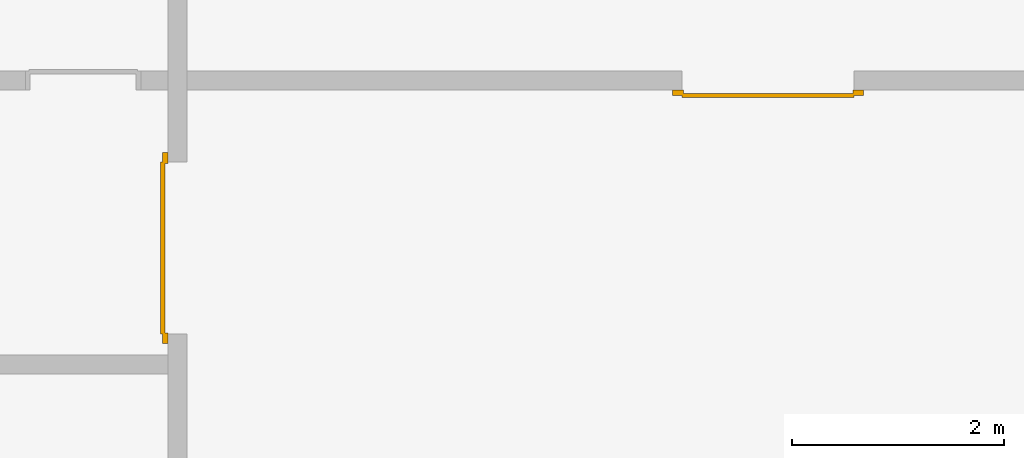
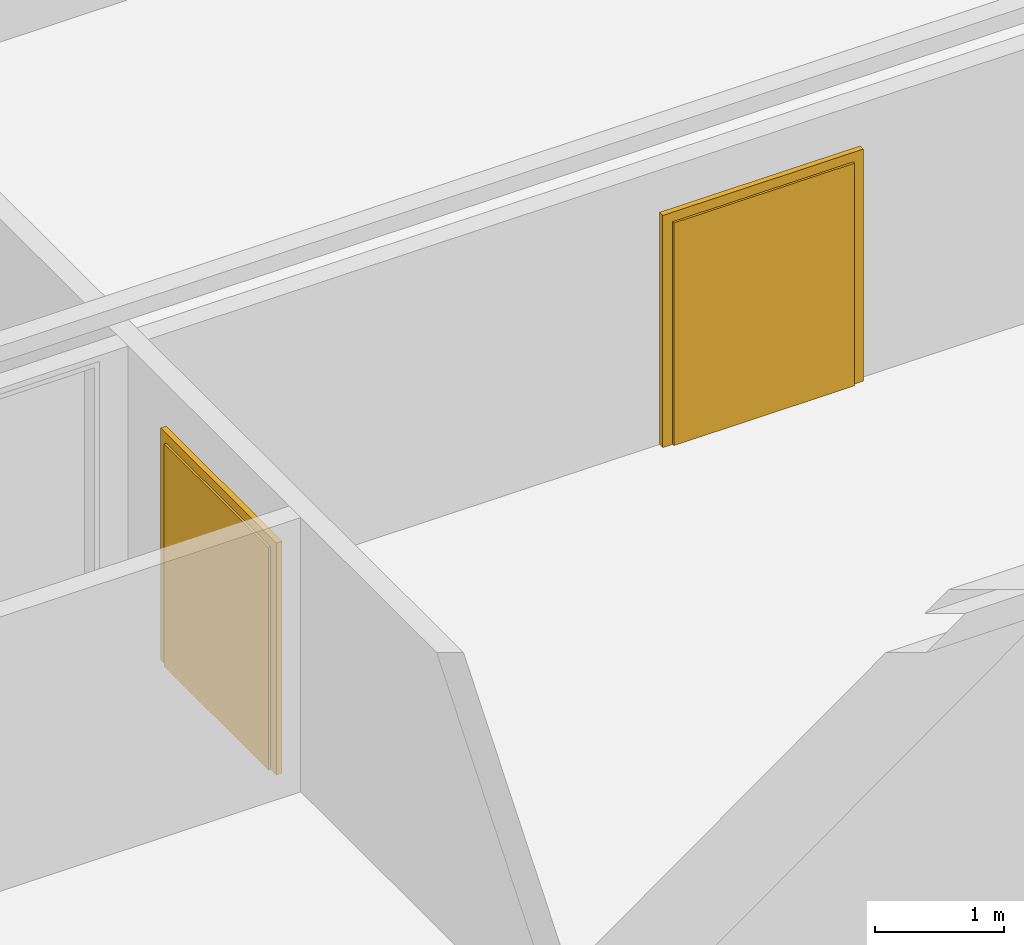
# One storey, part 3 of 5: 2 doors.
"""IFC4 building model written with IfcOpenShell, lengths in metres."""

import ifcopenshell
import ifcopenshell.guid

model = None  # the IFC model being written
_history = None  # IfcOwnerHistory: only IFC2X3 demands one
_inside = {}  # id of a spatial element -> (the spatial element, [elements in it])
_under = {}  # id of a project, library or spatial element -> (it, [spatial elements below it])
_declared = {}  # id of a project -> (the project, [libraries it declares])
_typed = {}  # id of a type object -> (the type object, [elements of that type])
_made_of = {}  # id of a material, layer set ... -> (it, [elements and type objects made of it])


def new_model(schema):
    """Start an empty IFC model of exactly this schema.

    Asked for "IFC4X3", IfcOpenShell would pick the latest addendum, in which some entities
    have other attributes; the version numbers below select the first issue.
    IFC2X3 requires an IfcOwnerHistory on every rooted entity: one is made here for all.
    """
    global model, _history
    if schema == "IFC4X3":
        model = ifcopenshell.file(schema_version=(4, 3, 0, 0))
    else:
        model = ifcopenshell.file(schema=schema)
    _inside.clear()
    _under.clear()
    _declared.clear()
    _typed.clear()
    _made_of.clear()
    _history = None
    if model.schema == "IFC2X3":
        org = make("IfcOrganization", Name="unknown")
        user = make(
            "IfcPersonAndOrganization",
            ThePerson=make("IfcPerson", FamilyName="unknown"),
            TheOrganization=org,
        )
        app = make(
            "IfcApplication",
            ApplicationDeveloper=org,
            Version="unknown",
            ApplicationFullName="unknown",
            ApplicationIdentifier="unknown",
        )
        _history = make(
            "IfcOwnerHistory",
            OwningUser=user,
            OwningApplication=app,
            ChangeAction="ADDED",
            CreationDate=0,
        )
    return model


def make(cls, **values):
    """One entity of the class cls with the attributes given. An attribute that is None is left unset."""
    return model.create_entity(
        cls, **{name: value for name, value in values.items() if value is not None}
    )


def entity(cls, *values):
    """Any entity or typed value of the class cls, its attributes in the order of the schema. None: left unset."""
    e = model.create_entity(cls)
    for i, value in enumerate(values):
        if value is not None:
            e[i] = value
    return e


def rooted(cls, **values):
    """An entity with a GlobalId (a new one), such as an element, a storey or a relation."""
    return make(cls, GlobalId=ifcopenshell.guid.new(), OwnerHistory=_history, **values)


def si_unit(unit_type, name, prefix=None):
    """IfcSIUnit, for example si_unit("LENGTHUNIT", "METRE", prefix="MILLI")."""
    return make("IfcSIUnit", UnitType=unit_type, Prefix=prefix, Name=name)


def converted_unit(unit_type, name, factor, base, dimensions=None, offset=None):
    """IfcConversionBasedUnit, such as the inch: factor (a typed value) times the base unit."""
    return make(
        "IfcConversionBasedUnit"
        if offset is None
        else "IfcConversionBasedUnitWithOffset",
        ConversionOffset=offset,
        Dimensions=None
        if dimensions is None
        else entity("IfcDimensionalExponents", *dimensions),
        UnitType=unit_type,
        Name=name,
        ConversionFactor=make(
            "IfcMeasureWithUnit", ValueComponent=factor, UnitComponent=base
        ),
    )


def derived_unit(unit_type, elements):
    """IfcDerivedUnit: a product of units, each with its exponent."""
    return make(
        "IfcDerivedUnit",
        Elements=[
            make("IfcDerivedUnitElement", Unit=unit, Exponent=power)
            for unit, power in elements
        ],
        UnitType=unit_type,
    )


def assignment(units):
    """IfcUnitAssignment: the units of a project."""
    return None if units is None else make("IfcUnitAssignment", Units=units)


def point(xyz):
    """IfcCartesianPoint."""
    return None if xyz is None else make("IfcCartesianPoint", Coordinates=xyz)


def direction(xyz):
    """IfcDirection."""
    return None if xyz is None else make("IfcDirection", DirectionRatios=xyz)


def frame(location, z_axis=None, x_axis=None):
    """IfcAxis2Placement3D, a coordinate frame: its origin and axes. An axis left out is left unset."""
    return make(
        "IfcAxis2Placement3D",
        Location=point(location),
        Axis=direction(z_axis),
        RefDirection=direction(x_axis),
    )


def origin_with_axes():
    """The frame at (0, 0, 0) with the z axis (0, 0, 1) and the x axis (1, 0, 0) written out."""
    return frame((0.0, 0.0, 0.0), z_axis=(0.0, 0.0, 1.0), x_axis=(1.0, 0.0, 0.0))


def place(relative_to, where):
    """IfcLocalPlacement: puts the frame where relative to a parent placement (None: the world)."""
    return make(
        "IfcLocalPlacement", PlacementRelTo=relative_to, RelativePlacement=where
    )


def context(
    kind, dimensions, precision=None, world=None, true_north=None, identifier=None
):
    """IfcGeometricRepresentationContext, for example the 3D "Model" context."""
    return make(
        "IfcGeometricRepresentationContext",
        ContextIdentifier=identifier,
        ContextType=kind,
        CoordinateSpaceDimension=dimensions,
        Precision=precision,
        WorldCoordinateSystem=world,
        TrueNorth=true_north,
    )


def subcontext(parent, identifier, kind, view, scale=None):
    """IfcGeometricRepresentationSubContext, for example "Body" below "Model"."""
    return make(
        "IfcGeometricRepresentationSubContext",
        ContextIdentifier=identifier,
        ContextType=kind,
        ParentContext=parent,
        TargetScale=scale,
        TargetView=view,
    )


def project(units=None, contexts=None):
    """IfcProject with its units and contexts."""
    return rooted(
        "IfcProject",
        Name="project",
        RepresentationContexts=contexts,
        UnitsInContext=assignment(units),
    )


def spatial(cls, under=None, at=None, **own):
    """A site, building, storey or space (cls), placed at a placement, below another one or the project."""
    s = rooted(cls, ObjectPlacement=at, **own)
    if under is not None:
        _under.setdefault(under.id(), (under, []))[1].append(s)
    return s


def point_list(points):
    """IfcCartesianPointList2D or 3D."""
    cls = (
        "IfcCartesianPointList2D" if len(points[0]) == 2 else "IfcCartesianPointList3D"
    )
    return make(cls, CoordList=points)


def polygons(points, faces, closed=None, point_numbers=None):
    """IfcPolygonalFaceSet: a face is its outer loop, then its inner loops; points numbered from 1."""
    made = []
    for loops in faces:
        if len(loops) == 1:
            made.append(make("IfcIndexedPolygonalFace", CoordIndex=loops[0]))
        else:
            made.append(
                make(
                    "IfcIndexedPolygonalFaceWithVoids",
                    CoordIndex=loops[0],
                    InnerCoordIndices=loops[1:],
                )
            )
    return make(
        "IfcPolygonalFaceSet",
        Coordinates=point_list(points),
        Closed=closed,
        Faces=made,
        PnIndex=point_numbers,
    )


def shape(context_of_items, identifier, shape_type, items):
    """IfcShapeRepresentation: the items that make up one representation, for example the "Body"."""
    return make(
        "IfcShapeRepresentation",
        ContextOfItems=context_of_items,
        RepresentationIdentifier=identifier,
        RepresentationType=shape_type,
        Items=items,
    )


def source(mapping_origin, context_of_items, identifier, shape_type, items):
    """IfcRepresentationMap: a shape defined once, which mapped items show again and again."""
    return make(
        "IfcRepresentationMap",
        MappingOrigin=mapping_origin,
        MappedRepresentation=shape(context_of_items, identifier, shape_type, items),
    )


def transform(
    local_origin,
    x_axis=None,
    y_axis=None,
    z_axis=None,
    scale=None,
    scale2=None,
    scale3=None,
    uniform=True,
):
    """IfcCartesianTransformationOperator3D, or its non-uniform kind. x_axis, y_axis, z_axis: its Axis1, 2, 3."""
    if uniform:
        return make(
            "IfcCartesianTransformationOperator3D",
            Axis1=direction(x_axis),
            Axis2=direction(y_axis),
            LocalOrigin=point(local_origin),
            Scale=scale,
            Axis3=direction(z_axis),
        )
    return make(
        "IfcCartesianTransformationOperator3DnonUniform",
        Axis1=direction(x_axis),
        Axis2=direction(y_axis),
        LocalOrigin=point(local_origin),
        Scale=scale,
        Axis3=direction(z_axis),
        Scale2=scale2,
        Scale3=scale3,
    )


def mapped(mapping_source, mapping_target):
    """IfcMappedItem: shows the shape of a source again, moved by a transform."""
    return make(
        "IfcMappedItem", MappingSource=mapping_source, MappingTarget=mapping_target
    )


def made_of(thing, what):
    """Note that an element or type object is made of a material, layer set ...; save() writes the relation."""
    if what is not None:
        _made_of.setdefault(what.id(), (what, []))[1].append(thing)
    return thing


def type_object(cls, material=None, **own):
    """A type object (cls), such as IfcWallType, which elements share."""
    return made_of(rooted(cls, **own), material)


def element(
    cls,
    number,
    at=None,
    inside=None,
    cuts=None,
    type_object=None,
    material=None,
    context=None,
    identifier="Body",
    shape_type=None,
    held_by="IfcProductDefinitionShape",
    body=None,
    shapes=None,
    **own,
):
    """One element of the class cls, such as IfcWall. Its Tag is "e" and its number.

    at: its placement. inside: the storey or other place that contains it. cuts: it is an
    opening in that element (IfcRelVoidsElement). A single representation is given by context,
    identifier, shape_type and body (its items); several are given by shapes. held_by: the class
    of the entity that holds the representations. save() writes the other relations.
    """
    e = rooted(cls, Tag="e%d" % number, ObjectPlacement=at, **own)
    if body is not None:
        shapes = [shape(context, identifier, shape_type, body)]
    if shapes is not None:
        e.Representation = make(held_by, Representations=shapes)
    if inside is not None:
        _inside.setdefault(inside.id(), (inside, []))[1].append(e)
    if cuts is not None:
        rooted(
            "IfcRelVoidsElement", RelatingBuildingElement=cuts, RelatedOpeningElement=e
        )
    if type_object is not None:
        _typed.setdefault(type_object.id(), (type_object, []))[1].append(e)
    return made_of(e, material)


def aggregate(whole, parts):
    """IfcRelAggregates: a whole, such as a stair, and the parts it consists of."""
    return rooted("IfcRelAggregates", RelatingObject=whole, RelatedObjects=parts)


def save(model, path):
    """Write the relations noted so far, then the file.

    IfcRelAggregates (storeys below a building ...), IfcRelContainedInSpatialStructure (elements
    in a storey), IfcRelDefinesByType, IfcRelAssociatesMaterial and IfcRelDeclares: one each for
    every whole, place, type object, material and project.
    """
    for whole, parts in _under.values():
        aggregate(whole, parts)
    for where, things in _inside.values():
        rooted(
            "IfcRelContainedInSpatialStructure",
            RelatedElements=things,
            RelatingStructure=where,
        )
    for kind, things in _typed.values():
        rooted("IfcRelDefinesByType", RelatedObjects=things, RelatingType=kind)
    for what, things in _made_of.values():
        rooted("IfcRelAssociatesMaterial", RelatedObjects=things, RelatingMaterial=what)
    for by, libraries in _declared.values():
        rooted("IfcRelDeclares", RelatingContext=by, RelatedDefinitions=libraries)
    model.write(path)


model = new_model("IFC4")

# Units and contexts
model_context = context("Model", 3, precision=1e-05, world=origin_with_axes(), true_north=direction((0.0, 1.0)))
body_context = subcontext(model_context, "Body", "Model", "MODEL_VIEW")
ifc_project = project(units=[si_unit("LENGTHUNIT", "METRE"), si_unit("AREAUNIT", "SQUARE_METRE"), si_unit("VOLUMEUNIT", "CUBIC_METRE"), converted_unit("PLANEANGLEUNIT", "DEGREE", entity("IfcPlaneAngleMeasure", 0.0174532925199433), si_unit("PLANEANGLEUNIT", "RADIAN"), dimensions=[0, 0, 0, 0, 0, 0, 0]), converted_unit("TIMEUNIT", "Year", entity("IfcTimeMeasure", 31557600.0), si_unit("TIMEUNIT", "SECOND"), dimensions=[0, 0, 1, 0, 0, 0, 0]), si_unit("MASSUNIT", "GRAM", prefix="KILO"), si_unit("THERMODYNAMICTEMPERATUREUNIT", "DEGREE_CELSIUS"), si_unit("LUMINOUSINTENSITYUNIT", "LUMEN"), si_unit("ENERGYUNIT", "JOULE", prefix="MEGA"), derived_unit("THERMALCONDUCTANCEUNIT", [(si_unit("POWERUNIT", "WATT"), 1), (si_unit("LENGTHUNIT", "METRE"), -1), (si_unit("THERMODYNAMICTEMPERATUREUNIT", "KELVIN"), -1)]), derived_unit("SPECIFICHEATCAPACITYUNIT", [(si_unit("ENERGYUNIT", "JOULE"), 1), (si_unit("MASSUNIT", "GRAM", prefix="KILO"), -1), (si_unit("THERMODYNAMICTEMPERATUREUNIT", "KELVIN"), -1)]), derived_unit("MASSDENSITYUNIT", [(si_unit("MASSUNIT", "GRAM", prefix="KILO"), 1), (si_unit("VOLUMEUNIT", "CUBIC_METRE"), -1)])], contexts=[model_context])

# Site, building, storey
site_placement = place(None, origin_with_axes())
site = spatial("IfcSite", under=ifc_project, at=site_placement, CompositionType="ELEMENT")
building_placement = place(None, origin_with_axes())
building = spatial("IfcBuilding", under=site, at=building_placement, CompositionType="ELEMENT")
storey_placement = place(None, frame((0.0, 0.0, -3.0), z_axis=(0.0, 0.0, 1.0), x_axis=(1.0, 0.0, 0.0)))
storey = spatial("IfcBuildingStorey", under=building, at=storey_placement, Name="UG", CompositionType="ELEMENT", Elevation=-3.0)

# Doors
door_type = type_object("IfcDoorType", OperationType="DOUBLE_DOOR_SINGLE_SWING", PredefinedType="DOOR")
shared_shape = source(origin_with_axes(), body_context, "Body", "Tessellation", [
    polygons([(-0.9, 0.0, 0.0), (-0.9, 0.0, 2.2), (-0.9, 0.03, 2.2), (-0.9, 0.03, 0.0), (-0.8, 0.0, 0.0), (-0.8, 0.0, 2.1), (-0.1101, 0.0, 2.1), (-0.0001, 0.0, 2.1), (0.8, 0.0, 2.1), (0.8, 0.0, 0.0), (0.9, 0.0, 0.0), (0.9, 0.0, 2.2), (0.9, 0.03, 2.2), (0.9, 0.03, 0.0), (0.8, 0.03, 0.0), (0.8, 0.03, 2.1), (-0.0001, 0.03, 2.1), (-0.1101, 0.03, 2.1), (-0.8, 0.03, 2.1), (-0.8, 0.03, 0.0)], [[[1, 2, 3, 4]], [[1, 5, 6, 7, 8, 9, 10, 11, 12, 2]], [[2, 12, 13, 3]], [[4, 3, 13, 14, 15, 16, 17, 18, 19, 20]], [[5, 1, 4, 20]], [[6, 5, 20, 19]], [[7, 6, 19, 18]], [[8, 7, 18, 17]], [[9, 8, 17, 16]], [[10, 9, 16, 15]], [[11, 10, 15, 14]], [[12, 11, 14, 13]]], closed=True),
    polygons([(-0.9, 0.03, 0.0), (-0.9, 0.03, 2.2), (-0.9, 0.05, 2.2), (-0.9, 0.05, 0.0), (-0.81, 0.03, 0.0), (-0.81, 0.03, 2.11), (-0.1001, 0.03, 2.11), (-0.0101, 0.03, 2.11), (0.81, 0.03, 2.11), (0.81, 0.03, 0.0), (0.9, 0.03, 0.0), (0.9, 0.03, 2.2), (0.9, 0.05, 2.2), (0.9, 0.05, 0.0), (0.81, 0.05, 0.0), (0.81, 0.05, 2.11), (-0.0101, 0.05, 2.11), (-0.1001, 0.05, 2.11), (-0.81, 0.05, 2.11), (-0.81, 0.05, 0.0)], [[[1, 2, 3, 4]], [[1, 5, 6, 7, 8, 9, 10, 11, 12, 2]], [[2, 12, 13, 3]], [[4, 3, 13, 14, 15, 16, 17, 18, 19, 20]], [[5, 1, 4, 20]], [[6, 5, 20, 19]], [[7, 6, 19, 18]], [[8, 7, 18, 17]], [[9, 8, 17, 16]], [[10, 9, 16, 15]], [[11, 10, 15, 14]], [[12, 11, 14, 13]]], closed=True),
    polygons([(-0.81, 0.07, 0.0), (-0.81, 0.07, 2.11), (-0.000499999999999945, 0.07, 2.11), (-0.000499999999999945, 0.07, 0.0), (-0.81, 0.03, 0.0), (-0.81, 0.03, 2.11), (-0.000499999999999945, 0.03, 2.11), (-0.000499999999999945, 0.03, 0.0)], [[[1, 2, 3, 4]], [[1, 5, 6, 2]], [[2, 6, 7, 3]], [[3, 7, 8, 4]], [[4, 8, 5, 1]], [[8, 7, 6, 5]]], closed=True),
    polygons([(0.81, 0.07, 0.0), (0.000499999999999945, 0.07, 0.0), (0.000499999999999945, 0.07, 2.11), (0.81, 0.07, 2.11), (0.81, 0.03, 0.0), (0.000499999999999945, 0.03, 0.0), (0.000499999999999945, 0.03, 2.11), (0.81, 0.03, 2.11)], [[[1, 2, 3, 4]], [[2, 1, 5, 6]], [[3, 2, 6, 7]], [[4, 3, 7, 8]], [[1, 4, 8, 5]], [[6, 5, 8, 7]]], closed=True),
])
door_1_placement = place(None, frame((39.968657642847, 7.05499994546755, -3.0), z_axis=(0.0, 0.0, 1.0), x_axis=(-1.0, 0.0, 0.0)))
element("IfcDoor", 1, at=door_1_placement, inside=storey, type_object=door_type, OverallHeight=2.11, OverallWidth=1.62, context=body_context, shape_type="MappedRepresentation", body=[
    mapped(shared_shape, transform((0.799999999999997, 0.0, 0.0))),
])
door_2_placement = place(None, frame((33.505, 4.76499994546756, -3.0), z_axis=(0.0, 0.0, 1.0), x_axis=(0.0, 1.0, 0.0)))
element("IfcDoor", 2, at=door_2_placement, inside=storey, type_object=door_type, OverallHeight=2.11, OverallWidth=1.62, context=body_context, shape_type="MappedRepresentation", body=[
    mapped(shared_shape, transform((0.8, 0.0, 0.0))),
])

save(model, "model.ifc")
